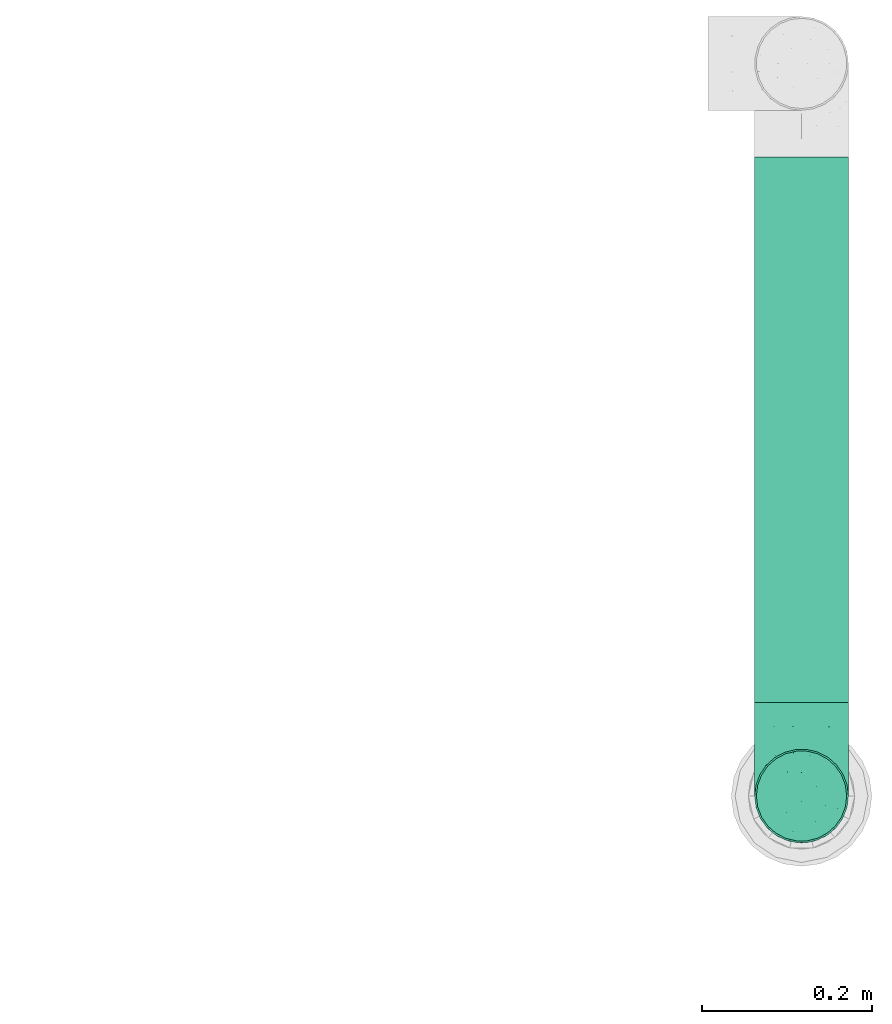
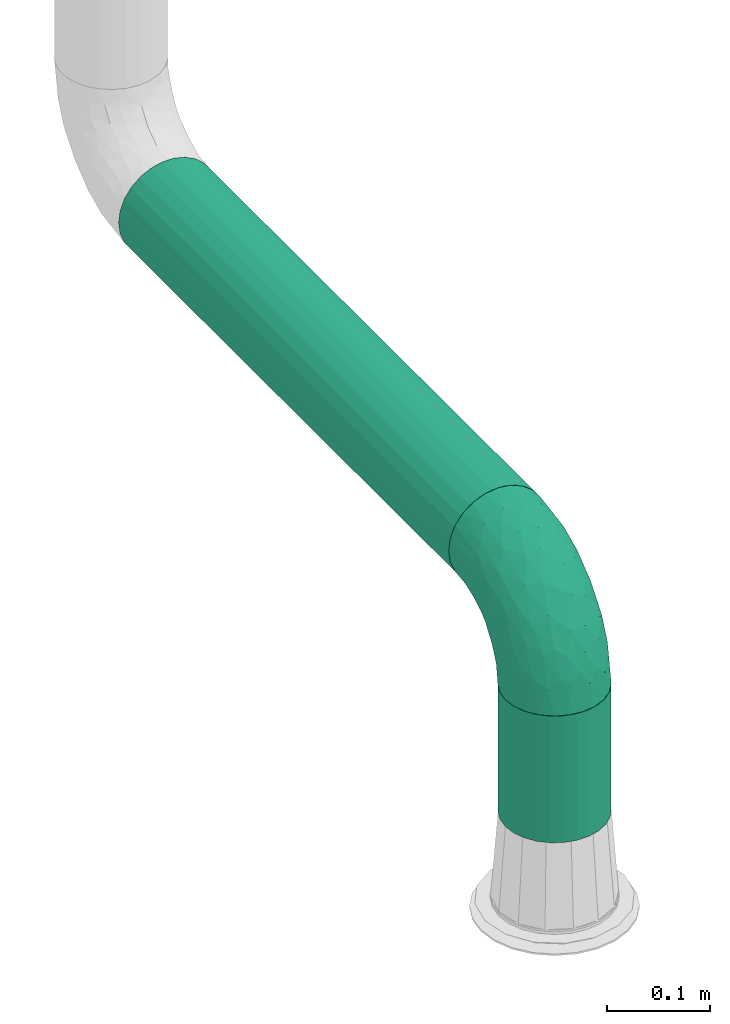
# One storey, part 109 of 123: 2 flow segments, 1 flow fitting.
"""IFC2X3 building model written with IfcOpenShell, lengths in millimetres."""

from ifc_helpers import new_model, entity, si_unit, converted_unit, derived_unit, direction, frame, origin_with_axes, origin_2d_with_axis, place, context, subcontext, project, spatial, hollow_circle, extrude, open_shell, surface_model, source, transform, mapped, material, layer, layer_set, layer_usage, type_object, element, save


model = new_model("IFC2X3")

# Units and contexts
model_context = context("Model", 3, precision=1e-05, world=origin_with_axes(), true_north=direction((0.0, 1.0)))
body_context = subcontext(model_context, "Body", "Model", "MODEL_VIEW")
ifc_project = project(units=[si_unit("AREAUNIT", "SQUARE_METRE"), si_unit("VOLUMEUNIT", "CUBIC_METRE", prefix="DECI"), si_unit("TIMEUNIT", "SECOND"), si_unit("THERMODYNAMICTEMPERATUREUNIT", "DEGREE_CELSIUS"), si_unit("PRESSUREUNIT", "PASCAL"), si_unit("MASSUNIT", "GRAM", prefix="KILO"), si_unit("LENGTHUNIT", "METRE", prefix="MILLI"), si_unit("POWERUNIT", "WATT"), si_unit("ELECTRICCURRENTUNIT", "AMPERE"), si_unit("ELECTRICVOLTAGEUNIT", "VOLT"), derived_unit("VOLUMETRICFLOWRATEUNIT", [(si_unit("VOLUMEUNIT", "CUBIC_METRE", prefix="DECI"), 1), (si_unit("TIMEUNIT", "SECOND"), -1)]), derived_unit("LINEARVELOCITYUNIT", [(si_unit("LENGTHUNIT", "METRE"), 1), (si_unit("TIMEUNIT", "SECOND"), -1)]), derived_unit("MASSDENSITYUNIT", [(si_unit("MASSUNIT", "GRAM", prefix="KILO"), 1), (si_unit("VOLUMEUNIT", "CUBIC_METRE"), -1)]), converted_unit("PLANEANGLEUNIT", "DEGREE", entity("IfcRatioMeasure", 0.01745), si_unit("PLANEANGLEUNIT", "RADIAN"), dimensions=[0, 0, 0, 0, 0, 0, 0])], contexts=[model_context])

# Site, building, storey
site_placement = place(None, origin_with_axes())
site = spatial("IfcSite", under=ifc_project, at=site_placement, CompositionType="ELEMENT")
building_placement = place(site_placement, origin_with_axes())
building = spatial("IfcBuilding", under=site, at=building_placement, Name="mc-building", CompositionType="ELEMENT")
storey_placement = place(building_placement, origin_with_axes())
storey = spatial("IfcBuildingStorey", under=building, at=storey_placement, Name="1. Korrus", CompositionType="ELEMENT", Elevation=0.0)

# Flow segment
ifc_material = material(Name="FZ1")
ifc_layer = layer(ifc_material, 0.0)
ifc_layer_set = layer_set([ifc_layer], Name="FZ1")
ifc_layer_usage = layer_usage(ifc_layer_set, "AXIS1", "POSITIVE", 0.0)
duct_segment_type = type_object("IfcDuctSegmentType", PredefinedType="RIGIDSEGMENT")
shared_shape_1 = source(origin_with_axes(), body_context, "Body", "SweptSolid", [
    extrude(hollow_circle(Radius=55.0, WallThickness=2.0, at=origin_2d_with_axis()), frame((0.0, 0.0, 0.0), z_axis=(1.0, 0.0, 0.0), x_axis=(0.0, 1.0, 0.0)), (0.0, 0.0, 1.0), 640.0),
])
flow_segment_1_placement = place(storey_placement, frame((37769.98441, 7274.97206, 5655.0), z_axis=(0.0, 0.0, 1.0), x_axis=(0.0, -1.0, 0.0)))
element("IfcFlowSegment", 1, at=flow_segment_1_placement, inside=storey, type_object=duct_segment_type, material=ifc_layer_usage, context=body_context, shape_type="MappedRepresentation", body=[
    mapped(shared_shape_1, transform((0.0, 0.0, 0.0), scale=1.0)),
])

# Flow fitting
duct_fitting_type = type_object("IfcDuctFittingType", Name="BU", PredefinedType="BEND")
shared_shape_2 = source(origin_with_axes(), body_context, "Body", "SurfaceModel", [
    surface_model("IfcShellBasedSurfaceModel", [(-110.0, 0.0, -55.0), (-110.0, -14.23505, -53.12592), (-110.0, 14.23505, -53.12592), (-110.0, 53.12592, 14.23505), (-110.0, 27.5, -47.63139), (-110.0, 38.89087, -38.89087), (-110.0, -55.0, 0.0), (-110.0, -53.12592, 14.23505), (-110.0, -38.89087, -38.89087), (-110.0, -27.5, -47.63139), (-110.0, -53.12592, -14.23505), (-110.0, -47.63139, -27.5), (-110.0, -14.23505, 53.12592), (-110.0, 14.23505, 53.12592), (-110.0, 27.5, 47.63139), (-110.0, -47.63139, 27.5), (-110.0, -38.89087, 38.89087), (-110.0, -27.5, 47.63139), (-110.0, 0.0, 55.0), (-110.0, 55.0, 0.0), (-110.0, 53.12592, -14.23505), (-110.0, 47.63139, -27.5), (-110.0, 47.63139, 27.5), (-110.0, 38.89087, 38.89087), (-14.23505, 110.0, -53.12592), (-55.0, 110.0, 0.0), (0.0, 110.0, -55.0), (-27.5, 110.0, -47.63139), (-38.89087, 110.0, -38.89087), (-47.63139, 110.0, -27.5), (38.89087, 110.0, -38.89087), (53.12592, 110.0, 14.23505), (27.5, 110.0, -47.63139), (14.23505, 110.0, -53.12592), (47.63139, 110.0, -27.5), (53.12592, 110.0, -14.23505), (55.0, 110.0, 0.0), (-53.12592, 110.0, -14.23505), (-53.12592, 110.0, 14.23505), (-47.63139, 110.0, 27.5), (-38.89087, 110.0, 38.89087), (-27.5, 110.0, 47.63139), (0.0, 110.0, 55.0), (-14.23505, 110.0, 53.12592), (38.89087, 110.0, 38.89087), (47.63139, 110.0, 27.5), (27.5, 110.0, 47.63139), (14.23505, 110.0, 53.12592), (-64.21732, 48.68956, 43.63444), (-76.6405, 38.18013, 45.55988), (-60.44912, 32.56953, 51.94617), (-76.00813, 5.38378, 55.0), (-90.15553, 11.94394, 54.09138), (-78.5998, 26.77405, 50.81338), (-70.18771, 18.55163, 54.03432), (-75.55424, 54.2118, 32.41257), (-93.27622, 45.77614, 33.48188), (-96.12334, 22.13664, 50.81337), (-21.00813, 45.34362, 55.0), (-18.36258, 70.48427, 54.04484), (-32.04182, 59.64019, 52.24446), (-63.88653, 74.77858, 17.99134), (-74.66383, 63.08407, 19.92123), (-63.60674, 66.07878, 29.97482), (-99.597, 52.72185, 18.52927), (-93.11138, 56.59448, 10.50359), (-98.21577, 57.34403, 0.0), (-53.42855, 92.60092, 21.04759), (-88.54852, 54.8376, 21.04759), (-11.86161, 90.23965, 54.10313), (-5.38378, 76.00813, 55.0), (-57.34403, 98.21577, 0.0), (-56.64619, 93.12774, 10.22088), (-45.34362, 21.00813, 55.0), (-44.60838, 44.60838, 52.13415), (-92.68484, 35.46673, 43.63443), (-22.25266, 95.40765, 50.81337), (-35.97783, 90.61597, 43.63443), (-43.70931, 69.58671, 44.47149), (-27.23711, 77.39884, 50.81337), (-57.2828, 79.3123, 24.9774), (-58.67786, 84.31125, 16.04456), (-82.93277, 60.36161, 12.91784), (-49.88337, 54.51816, 47.224), (-74.57753, 66.83759, 9.55742), (-45.35812, 94.97281, 33.48188), (-59.18663, 88.95241, 0.0), (-51.517, 78.6292, 33.48188), (-65.14788, 80.03077, 0.0), (-56.45322, 62.06476, 39.63545), (-88.95241, 59.18663, 0.0), (-71.10913, 71.10913, 0.0), (-80.03077, 65.14788, 0.0), (-94.9309, 45.36788, -33.48188), (-93.11358, 56.60141, -10.46614), (-99.64997, 52.79499, -18.30015), (-90.20425, 36.08686, -43.63443), (-79.99933, 46.56772, -37.92748), (-76.00813, 5.38378, -55.0), (-72.75364, 19.68651, -53.60527), (-45.34362, 21.00813, -55.0), (-21.91957, 65.12078, -53.85897), (-5.38378, 76.00813, -55.0), (-21.00813, 45.34362, -55.0), (-35.41876, 92.89265, -43.63443), (-91.10309, 11.02766, -54.21832), (-45.77614, 93.27622, -33.48188), (-90.50474, 23.21022, -50.81337), (-70.92854, 33.31794, -49.51754), (-78.52933, 63.35627, -11.73997), (-24.91508, 84.05606, -50.81337), (-88.78941, 54.74452, -21.04759), (-69.59921, 57.34866, -33.48187), (-73.36422, 62.46673, -22.94182), (-63.49062, 67.59111, -28.46929), (-56.59448, 93.11138, -10.50359), (-54.8376, 88.54852, -21.04759), (-54.10679, 75.85581, -32.31867), (-57.75956, 31.09612, -52.80882), (-52.72185, 99.597, -18.52927), (-12.62913, 89.46304, -53.99097), (-34.46825, 66.46123, -50.04329), (-43.9837, 43.9837, -52.42279), (-65.78527, 72.58348, -17.68796), (-70.34468, 43.65295, -44.21951), (-57.47001, 51.99467, -44.91465), (-60.72547, 82.29174, -12.88567), (-42.34915, 74.24548, -43.63444), (-57.25194, 63.5016, -38.08211), (-80.95344, 53.56991, -29.32027), (-52.32891, 4.55257, -54.0482), (32.52942, 47.13398, -30.48571), (14.88266, 20.92917, -33.7947), (14.95561, 36.05775, -42.26543), (30.24048, 70.09027, -41.7461), (19.3559, 65.35825, -48.00507), (-70.35075, -46.44478, -19.5952), (-47.13398, -32.52942, -30.48571), (-28.49299, -30.5778, -16.4009), (-4.55257, 52.32891, -54.0482), (-22.4954, 22.4954, -53.25347), (-75.47368, -11.22546, -52.60718), (-81.32209, -51.5606, -9.98467), (-80.81763, -41.84862, -32.14655), (-70.09027, -30.24048, -41.7461), (-36.05774, -14.95561, -42.26543), (-9.15831, -10.852, -27.8997), (-65.35825, -19.3559, -48.00507), (11.22546, 75.47368, -52.60718), (3.94376, 43.9333, -50.53315), (-13.39742, 13.39743, -48.13058), (-43.9333, -3.94376, -50.53315), (49.37776, 67.29486, 0.0), (41.8609, 47.82256, -9.92641), (50.20582, 74.51695, -9.9731), (18.93131, 11.7156, -17.56239), (-27.5, -32.89419, 0.0), (-1.23348, -12.25375, -12.18106), (41.84862, 80.81763, -32.14655), (35.70604, 41.31408, -20.38235), (46.44478, 70.35075, -19.5952), (32.89419, 27.5, 0.0), (6.67262, -6.67262, 0.0), (-67.29486, -49.37776, 0.0), (-50.36265, -42.95545, -9.51562), (-5.47251, 5.47251, -39.92906), (-70.35075, -46.44478, 19.5952), (-74.51695, -50.20582, 9.9731), (-41.31407, -35.70604, 20.38235), (-47.13398, -32.52942, 30.48571), (-80.81763, -41.84862, 32.14655), (-4.55257, 52.32891, 54.0482), (11.22546, 75.47368, 52.60718), (-43.9333, -3.94376, 50.53315), (-65.35825, -19.3559, 48.00507), (-36.05774, -14.95561, 42.26543), (-70.09027, -30.24048, 41.7461), (-11.7156, -18.93131, 17.56239), (30.5778, 28.49299, 16.4009), (12.25375, 1.23348, 12.18106), (51.5606, 81.32209, 9.98467), (42.95545, 50.36265, 9.51562), (-75.47368, -11.22546, 52.60718), (-52.32891, 4.55257, 54.0482), (3.94376, 43.9333, 50.53315), (-22.4954, 22.4954, 53.25347), (-13.39742, 13.39743, 48.13058), (10.852, 9.15831, 27.8997), (-20.92916, -14.88266, 33.79469), (-47.82256, -41.8609, 9.92641), (32.52942, 47.13398, 30.48571), (46.44478, 70.35075, 19.5952), (41.84862, 80.81763, 32.14655), (30.24048, 70.09027, 41.7461), (19.3559, 65.35825, 48.00507), (14.95561, 36.05775, 42.26543), (-5.47251, 5.47251, 39.92906)], [open_shell([[[0, 1, 2]], [[2, 3, 4]], [[4, 3, 5]], [[2, 6, 7]], [[8, 6, 9]], [[1, 9, 6]], [[10, 6, 11]], [[8, 11, 6]], [[6, 2, 1]], [[12, 13, 14]], [[15, 2, 7]], [[16, 17, 2]], [[2, 17, 12]], [[12, 18, 13]], [[19, 20, 3]], [[5, 3, 21]], [[20, 21, 3]], [[22, 3, 2]], [[23, 22, 2]], [[12, 14, 2]], [[2, 14, 23]], [[15, 16, 2]], [[24, 25, 26]], [[27, 25, 24]], [[25, 28, 29]], [[28, 25, 27]], [[30, 26, 31]], [[26, 30, 32]], [[32, 33, 26]], [[34, 31, 35]], [[31, 34, 30]], [[35, 31, 36]], [[29, 37, 25]], [[38, 39, 26]], [[39, 40, 26]], [[41, 42, 40]], [[42, 26, 40]], [[42, 41, 43]], [[26, 44, 45]], [[31, 26, 45]], [[26, 46, 44]], [[47, 46, 26]], [[42, 47, 26]], [[25, 38, 26]], [[48, 49, 50]], [[18, 51, 52]], [[53, 54, 50]], [[55, 56, 49]], [[56, 22, 23]], [[13, 57, 14]], [[58, 59, 60]], [[61, 62, 63]], [[3, 64, 65]], [[53, 52, 54]], [[3, 65, 66]], [[67, 39, 38]], [[56, 68, 64]], [[65, 64, 68]], [[69, 59, 70]], [[38, 71, 72]], [[73, 58, 74]], [[75, 49, 56]], [[76, 69, 43]], [[53, 57, 52]], [[77, 78, 79]], [[41, 76, 43]], [[43, 69, 42]], [[55, 68, 56]], [[23, 14, 75]], [[76, 77, 79]], [[80, 67, 81]], [[62, 82, 68]], [[60, 78, 83]], [[62, 84, 82]], [[85, 77, 40]], [[81, 67, 72]], [[86, 72, 71]], [[87, 85, 67]], [[61, 81, 88]], [[77, 41, 40]], [[78, 77, 87]], [[23, 75, 56]], [[83, 89, 48]], [[85, 40, 39]], [[62, 68, 55]], [[89, 87, 63]], [[83, 48, 50]], [[57, 75, 14]], [[49, 75, 53]], [[67, 85, 39]], [[87, 77, 85]], [[63, 62, 55]], [[89, 55, 48]], [[80, 63, 87]], [[66, 65, 90]], [[66, 19, 3]], [[84, 91, 92]], [[92, 90, 82]], [[65, 82, 90]], [[61, 84, 62]], [[92, 82, 84]], [[68, 82, 65]], [[3, 22, 64]], [[56, 64, 22]], [[38, 25, 71]], [[81, 72, 86]], [[38, 72, 67]], [[91, 61, 88]], [[80, 81, 61]], [[63, 80, 61]], [[67, 80, 87]], [[77, 76, 41]], [[79, 59, 69]], [[79, 69, 76]], [[42, 69, 70]], [[60, 59, 79]], [[58, 70, 59]], [[78, 60, 79]], [[58, 60, 74]], [[52, 57, 13]], [[75, 57, 53]], [[18, 52, 13]], [[52, 51, 54]], [[51, 73, 54]], [[50, 73, 74]], [[73, 50, 54]], [[50, 74, 83]], [[60, 83, 74]], [[89, 83, 78]], [[87, 89, 78]], [[55, 89, 63]], [[50, 49, 53]], [[55, 49, 48]], [[81, 86, 88]], [[91, 84, 61]], [[5, 21, 93]], [[90, 94, 66]], [[20, 94, 95]], [[96, 93, 97]], [[98, 99, 100]], [[96, 4, 5]], [[101, 102, 103]], [[28, 27, 104]], [[2, 105, 0]], [[104, 106, 28]], [[99, 105, 107]], [[108, 107, 96]], [[90, 109, 94]], [[107, 2, 4]], [[20, 66, 94]], [[27, 24, 110]], [[109, 111, 94]], [[112, 113, 114]], [[37, 115, 71]], [[116, 106, 117]], [[99, 118, 100]], [[116, 115, 119]], [[37, 119, 115]], [[24, 120, 110]], [[121, 110, 101]], [[119, 106, 116]], [[101, 110, 120]], [[122, 103, 100]], [[117, 123, 116]], [[124, 125, 108]], [[115, 116, 126]], [[106, 29, 28]], [[26, 102, 120]], [[127, 104, 110]], [[97, 124, 96]], [[125, 122, 118]], [[128, 127, 125]], [[96, 5, 93]], [[115, 126, 86]], [[117, 106, 127]], [[111, 113, 129]], [[95, 93, 21]], [[97, 129, 112]], [[110, 104, 27]], [[106, 104, 127]], [[96, 107, 4]], [[99, 107, 108]], [[99, 108, 118]], [[105, 99, 98]], [[112, 114, 128]], [[121, 125, 127]], [[20, 19, 66]], [[109, 90, 92]], [[94, 111, 95]], [[91, 123, 109]], [[129, 113, 112]], [[93, 95, 111]], [[21, 20, 95]], [[71, 115, 86]], [[71, 25, 37]], [[123, 91, 88]], [[126, 116, 123]], [[123, 88, 126]], [[86, 126, 88]], [[37, 29, 119]], [[106, 119, 29]], [[129, 93, 111]], [[124, 112, 125]], [[0, 105, 98]], [[107, 105, 2]], [[125, 118, 108]], [[100, 118, 122]], [[93, 129, 97]], [[113, 111, 109]], [[109, 123, 113]], [[114, 123, 117]], [[123, 114, 113]], [[128, 114, 117]], [[127, 128, 117]], [[112, 128, 125]], [[103, 122, 101]], [[110, 121, 127]], [[101, 122, 121]], [[125, 121, 122]], [[26, 120, 24]], [[101, 120, 102]], [[96, 124, 108]], [[92, 91, 109]], [[112, 124, 97]], [[100, 130, 98]], [[131, 132, 133]], [[32, 134, 135]], [[136, 137, 138]], [[139, 140, 103]], [[98, 141, 0]], [[142, 10, 136]], [[143, 144, 137]], [[6, 10, 142]], [[137, 145, 146]], [[144, 147, 145]], [[143, 136, 11]], [[11, 136, 10]], [[8, 143, 11]], [[148, 149, 139]], [[8, 9, 144]], [[9, 1, 147]], [[130, 141, 98]], [[103, 140, 100]], [[148, 135, 149]], [[150, 151, 140]], [[152, 153, 154]], [[130, 140, 151]], [[148, 26, 33]], [[147, 1, 141]], [[155, 146, 132]], [[156, 138, 157]], [[134, 30, 158]], [[150, 140, 149]], [[158, 30, 34]], [[30, 134, 32]], [[153, 159, 160]], [[131, 160, 159]], [[144, 145, 137]], [[36, 152, 154]], [[146, 138, 137]], [[155, 161, 162]], [[158, 160, 131]], [[133, 149, 135]], [[156, 163, 164]], [[163, 142, 164]], [[139, 103, 102]], [[153, 152, 161]], [[34, 35, 160]], [[162, 157, 155]], [[132, 165, 133]], [[157, 146, 155]], [[140, 130, 100]], [[141, 130, 151]], [[141, 151, 147]], [[141, 1, 0]], [[102, 26, 148]], [[140, 139, 149]], [[102, 148, 139]], [[135, 33, 32]], [[151, 150, 145]], [[9, 147, 144]], [[151, 145, 147]], [[145, 165, 146]], [[135, 148, 33]], [[133, 135, 134]], [[131, 133, 134]], [[133, 165, 150]], [[133, 150, 149]], [[145, 150, 165]], [[132, 131, 159]], [[146, 165, 132]], [[160, 158, 34]], [[134, 158, 131]], [[144, 143, 8]], [[136, 143, 137]], [[155, 153, 161]], [[154, 153, 160]], [[153, 155, 159]], [[132, 159, 155]], [[160, 35, 154]], [[36, 154, 35]], [[164, 136, 138]], [[6, 142, 163]], [[136, 164, 142]], [[156, 164, 138]], [[156, 157, 162]], [[146, 157, 138]], [[15, 7, 166]], [[6, 163, 167]], [[168, 169, 166]], [[166, 169, 170]], [[171, 172, 70]], [[173, 174, 175]], [[17, 176, 174]], [[177, 156, 162]], [[176, 16, 170]], [[170, 16, 15]], [[161, 178, 179]], [[152, 180, 181]], [[182, 173, 183]], [[18, 12, 182]], [[184, 185, 186]], [[183, 185, 73]], [[183, 73, 51]], [[177, 187, 188]], [[189, 168, 166]], [[187, 178, 190]], [[16, 176, 17]], [[161, 152, 181]], [[45, 191, 31]], [[45, 44, 192]], [[192, 191, 45]], [[180, 36, 31]], [[193, 194, 195]], [[46, 47, 194]], [[193, 195, 190]], [[193, 44, 46]], [[172, 42, 70]], [[185, 58, 73]], [[189, 163, 156]], [[163, 189, 167]], [[70, 58, 171]], [[184, 171, 185]], [[169, 188, 175]], [[180, 31, 191]], [[192, 193, 190]], [[191, 190, 178]], [[182, 174, 173]], [[194, 47, 172]], [[190, 195, 187]], [[186, 185, 173]], [[162, 179, 177]], [[188, 196, 175]], [[179, 187, 177]], [[185, 171, 58]], [[172, 171, 184]], [[172, 184, 194]], [[172, 47, 42]], [[51, 18, 182]], [[185, 183, 173]], [[51, 182, 183]], [[174, 12, 17]], [[184, 186, 195]], [[46, 194, 193]], [[184, 195, 194]], [[195, 196, 187]], [[174, 182, 12]], [[175, 174, 176]], [[169, 175, 176]], [[175, 196, 186]], [[175, 186, 173]], [[195, 186, 196]], [[188, 169, 168]], [[187, 196, 188]], [[166, 170, 15]], [[176, 170, 169]], [[193, 192, 44]], [[191, 192, 190]], [[177, 189, 156]], [[167, 189, 166]], [[189, 177, 168]], [[188, 168, 177]], [[166, 7, 167]], [[6, 167, 7]], [[181, 191, 178]], [[36, 180, 152]], [[191, 181, 180]], [[161, 181, 178]], [[161, 179, 162]], [[187, 179, 178]]])]),
])
flow_fitting_placement = place(storey_placement, frame((37769.98441, 6524.97206, 5655.0), z_axis=(1.0, 0.0, 0.0), x_axis=(0.0, -1.0, 0.0)))
element("IfcFlowFitting", 2, at=flow_fitting_placement, inside=storey, type_object=duct_fitting_type, Name="BU", context=body_context, shape_type="MappedRepresentation", body=[
    mapped(shared_shape_2, transform((0.0, 0.0, 0.0), scale=1.0)),
])

# Flow segment
shared_shape_3 = source(origin_with_axes(), body_context, "Body", "SweptSolid", [
    extrude(hollow_circle(Radius=55.0, WallThickness=2.0, at=origin_2d_with_axis()), frame((0.0, 0.0, 0.0), z_axis=(1.0, 0.0, 0.0), x_axis=(0.0, 1.0, 0.0)), (0.0, 0.0, 1.0), 150.0),
])
flow_segment_2_placement = place(storey_placement, frame((37769.98441, 6524.97206, 5545.0), z_axis=(0.0, -1.0, 0.0), x_axis=(0.0, 0.0, -1.0)))
element("IfcFlowSegment", 3, at=flow_segment_2_placement, inside=storey, type_object=duct_segment_type, material=ifc_layer_usage, context=body_context, shape_type="MappedRepresentation", body=[
    mapped(shared_shape_3, transform((0.0, 0.0, 0.0), scale=1.0)),
])

save(model, "model.ifc")
